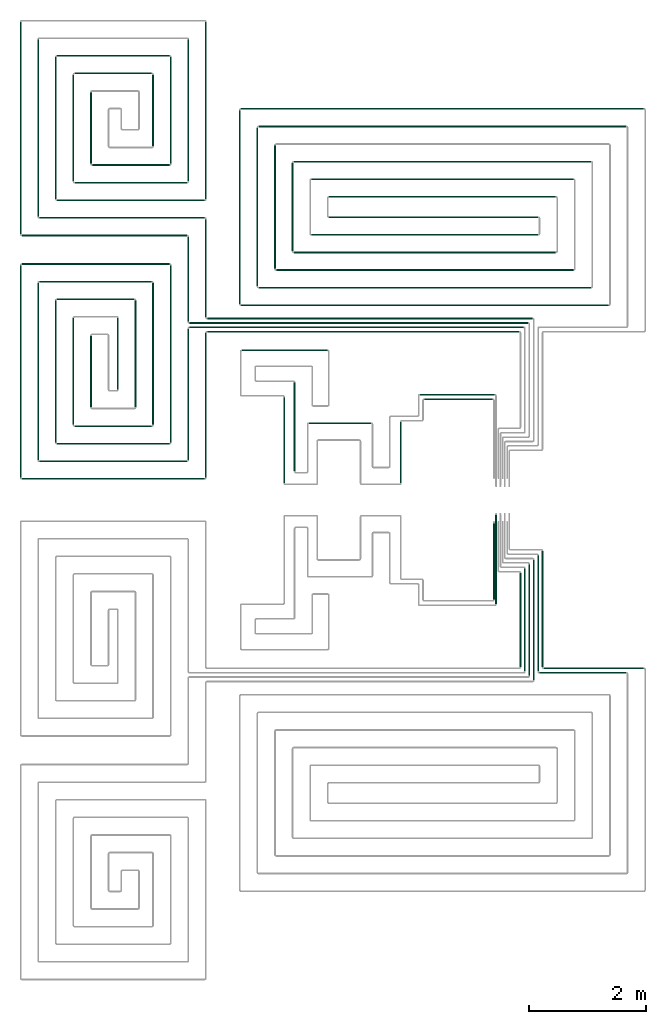
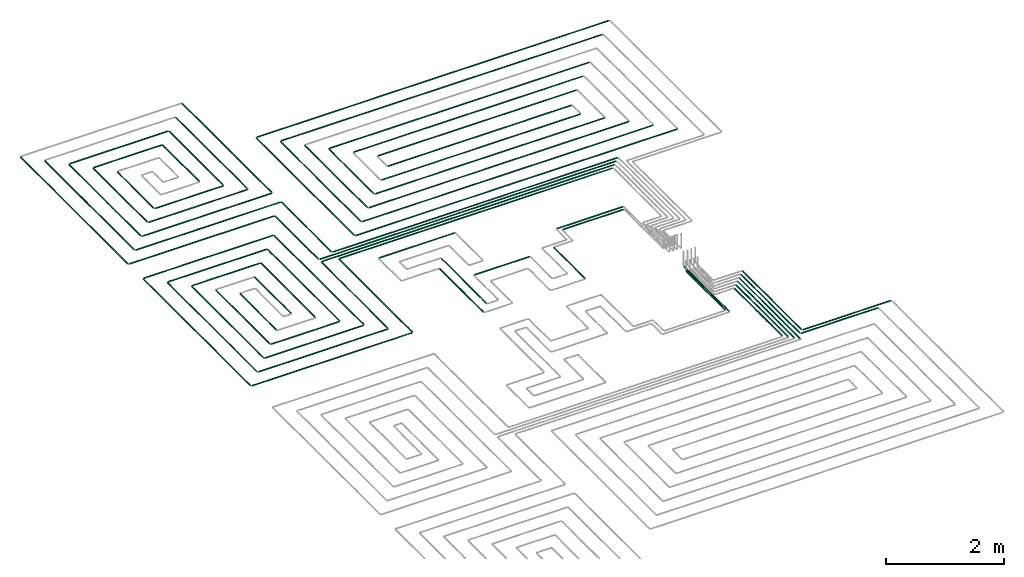
# One storey, part 2 of 12: 72 flow segments.
"""IFC2X3 building model written with IfcOpenShell, lengths in millimetres."""

from ifc_helpers import new_model, entity, si_unit, converted_unit, derived_unit, direction, frame, frame_2d, origin, origin_2d_with_axis, place, context, subcontext, project, spatial, circle, extrude, type_object, element, save


model = new_model("IFC2X3")

# Units and contexts
model_context = context("Model", 3, precision=0.01, world=origin(), true_north=direction((6.12303176911189e-17, 1.0)))
body_context = subcontext(model_context, "Body", "Model", "MODEL_VIEW")
ifc_project = project(units=[si_unit("LENGTHUNIT", "METRE", prefix="MILLI"), si_unit("AREAUNIT", "SQUARE_METRE"), si_unit("VOLUMEUNIT", "CUBIC_METRE"), converted_unit("PLANEANGLEUNIT", "DEGREE", entity("IfcRatioMeasure", 0.0174532925199433), si_unit("PLANEANGLEUNIT", "RADIAN"), dimensions=[0, 0, 0, 0, 0, 0, 0]), si_unit("MASSUNIT", "GRAM", prefix="KILO"), derived_unit("MASSDENSITYUNIT", [(si_unit("MASSUNIT", "GRAM", prefix="KILO"), 1), (si_unit("LENGTHUNIT", "METRE"), -3)]), si_unit("TIMEUNIT", "SECOND"), si_unit("FREQUENCYUNIT", "HERTZ"), si_unit("THERMODYNAMICTEMPERATUREUNIT", "DEGREE_CELSIUS"), derived_unit("THERMALTRANSMITTANCEUNIT", [(si_unit("MASSUNIT", "GRAM", prefix="KILO"), 1), (si_unit("THERMODYNAMICTEMPERATUREUNIT", "KELVIN"), -1), (si_unit("TIMEUNIT", "SECOND"), -3)]), derived_unit("VOLUMETRICFLOWRATEUNIT", [(si_unit("LENGTHUNIT", "METRE"), 3), (si_unit("TIMEUNIT", "SECOND"), -1)]), si_unit("ELECTRICCURRENTUNIT", "AMPERE"), si_unit("ELECTRICVOLTAGEUNIT", "VOLT"), si_unit("POWERUNIT", "WATT"), si_unit("FORCEUNIT", "NEWTON", prefix="KILO"), si_unit("ILLUMINANCEUNIT", "LUX"), si_unit("LUMINOUSFLUXUNIT", "LUMEN"), si_unit("LUMINOUSINTENSITYUNIT", "CANDELA"), derived_unit("USERDEFINED", [(si_unit("MASSUNIT", "GRAM", prefix="KILO"), -1), (si_unit("LENGTHUNIT", "METRE"), -2), (si_unit("TIMEUNIT", "SECOND"), 3), (si_unit("LUMINOUSFLUXUNIT", "LUMEN"), 1)]), derived_unit("LINEARVELOCITYUNIT", [(si_unit("LENGTHUNIT", "METRE"), 1), (si_unit("TIMEUNIT", "SECOND"), -1)]), si_unit("PRESSUREUNIT", "PASCAL"), derived_unit("USERDEFINED", [(si_unit("LENGTHUNIT", "METRE"), -2), (si_unit("MASSUNIT", "GRAM", prefix="KILO"), 1), (si_unit("TIMEUNIT", "SECOND"), -2)])], contexts=[model_context])

# Site, building, storey
site_placement = place(None, origin())
site = spatial("IfcSite", under=ifc_project, at=site_placement, CompositionType="ELEMENT")
building_placement = place(site_placement, origin())
building = spatial("IfcBuilding", under=site, at=building_placement, CompositionType="ELEMENT")
storey_placement = place(building_placement, frame((0.0, 0.0, 4000.0)))
storey = spatial("IfcBuildingStorey", under=building, at=storey_placement, Name="01 Level", CompositionType="ELEMENT", Elevation=4000.0)

# Flow segments
pipe_segment_type = type_object("IfcPipeSegmentType", PredefinedType="NOTDEFINED")
flow_segment_1_placement = place(storey_placement, frame((26623.6855494475, -71711.6450070283, -81.5952722359161)))
element("IfcFlowSegment", 1, at=flow_segment_1_placement, inside=storey, type_object=pipe_segment_type, context=body_context, shape_type="SweptSolid", body=[
    extrude(circle(Radius=10.0, at=origin_2d_with_axis()), frame((0.0, 11.5952722359136, 11.5952722359158), z_axis=(1.0, 0.0, 0.0), x_axis=(0.0, -1.0, 0.0)), (0.0, 0.0, 1.0), 1709.41153197237),
])
flow_segment_2_placement = place(storey_placement, frame((26548.6855494475, -71786.6450070283, -81.5952722359161)))
element("IfcFlowSegment", 2, at=flow_segment_2_placement, inside=storey, type_object=pipe_segment_type, context=body_context, shape_type="SweptSolid", body=[
    extrude(circle(Radius=10.0, at=origin_2d_with_axis()), frame((0.0, 11.5952722359136, 11.5952722359158), z_axis=(1.0, 0.0, 0.0), x_axis=(0.0, -1.0, 0.0)), (0.0, 0.0, 1.0), 1484.41153197236),
])
flow_segment_3_placement = place(storey_placement, frame((26442.0902772116, -71905.0497347924, -81.5952722359193)))
element("IfcFlowSegment", 3, at=flow_segment_3_placement, inside=storey, type_object=pipe_segment_type, context=body_context, shape_type="SweptSolid", body=[
    extrude(circle(Radius=10.0, at=origin_2d_with_axis()), frame((11.595272235918, 0.0, 11.5952722359158), z_axis=(0.0, 1.0, 0.0), x_axis=(-1.0, 0.0, 0.0)), (0.0, 0.0, 1.0), 2056.31014965248),
])
flow_segment_4_placement = place(storey_placement, frame((26367.0902772116, -71830.0497347924, -81.5952722359161)))
element("IfcFlowSegment", 4, at=flow_segment_4_placement, inside=storey, type_object=pipe_segment_type, context=body_context, shape_type="SweptSolid", body=[
    extrude(circle(Radius=10.0, at=origin_2d_with_axis()), frame((11.5952722359266, 0.0, 11.5952722359158), z_axis=(0.0, 1.0, 0.0), x_axis=(1.0, 0.0, 0.0)), (0.0, 0.0, 1.0), 1906.31014965249),
])
flow_segment_5_placement = place(storey_placement, frame((26292.0902772116, -71755.0497347924, -81.5952722359161)))
element("IfcFlowSegment", 5, at=flow_segment_5_placement, inside=storey, type_object=pipe_segment_type, context=body_context, shape_type="SweptSolid", body=[
    extrude(circle(Radius=10.0, at=origin_2d_with_axis()), frame((11.595272235918, 0.0, 11.5952722359158), z_axis=(0.0, 1.0, 0.0), x_axis=(1.0, 0.0, 0.0)), (0.0, 0.0, 1.0), 1756.31014965249),
])
flow_segment_6_placement = place(storey_placement, frame((26217.0902772116, -71680.0497347924, -81.5952722359193)))
element("IfcFlowSegment", 6, at=flow_segment_6_placement, inside=storey, type_object=pipe_segment_type, context=body_context, shape_type="SweptSolid", body=[
    extrude(circle(Radius=10.0, at=frame_2d((-4.33146851719357e-12, 0.0), x_axis=(1.0, 0.0))), frame((11.595272235918, 0.0, 11.5952722359158), z_axis=(0.0, 1.0, 0.0), x_axis=(-1.0, 0.0, 0.0)), (0.0, 0.0, 1.0), 1606.3101496525),
])
flow_segment_7_placement = place(storey_placement, frame((26592.0902772116, -71680.0497347924, -81.5952722359193)))
element("IfcFlowSegment", 7, at=flow_segment_7_placement, inside=storey, type_object=pipe_segment_type, context=body_context, shape_type="SweptSolid", body=[
    extrude(circle(Radius=10.0, at=frame_2d((4.33146851719357e-12, 0.0), x_axis=(1.0, 0.0))), frame((11.5952722359266, 0.0, 11.5952722359158), z_axis=(0.0, 1.0, 0.0), x_axis=(-1.0, 0.0, 0.0)), (0.0, 0.0, 1.0), 1981.31014965248),
])
flow_segment_8_placement = place(storey_placement, frame((26517.0902772116, -71755.0497347924, -81.5952722359161)))
element("IfcFlowSegment", 8, at=flow_segment_8_placement, inside=storey, type_object=pipe_segment_type, context=body_context, shape_type="SweptSolid", body=[
    extrude(circle(Radius=10.0, at=origin_2d_with_axis()), frame((11.5952722359266, 0.0, 11.5952722359158), z_axis=(0.0, 1.0, 0.0), x_axis=(1.0, 0.0, 0.0)), (0.0, 0.0, 1.0), 1981.31014965249),
])
flow_segment_9_placement = place(storey_placement, frame((25764.4416997349, -70531.3143518619, -81.5952722359248)))
element("IfcFlowSegment", 9, at=flow_segment_9_placement, inside=storey, type_object=pipe_segment_type, context=body_context, shape_type="SweptSolid", body=[
    extrude(circle(Radius=10.0, at=origin_2d_with_axis()), frame((11.595272235918, 0.0, 11.5952722359158), z_axis=(0.0, 1.0, 0.0), x_axis=(1.0, 0.0, 0.0)), (0.0, 0.0, 1.0), 1305.07476672193),
])
flow_segment_10_placement = place(storey_placement, frame((25799.4416997349, -70606.3143518619, -81.5952722359302)))
element("IfcFlowSegment", 10, at=flow_segment_10_placement, inside=storey, type_object=pipe_segment_type, context=body_context, shape_type="SweptSolid", body=[
    extrude(circle(Radius=10.0, at=origin_2d_with_axis()), frame((11.595272235918, 0.0, 11.5952722359158), z_axis=(0.0, 1.0, 0.0), x_axis=(1.0, 0.0, 0.0)), (0.0, 0.0, 1.0), 1520.07476672191),
])
flow_segment_11_placement = place(storey_placement, frame((20884.4386293741, -65974.0247077234, -81.5952722359175)))
element("IfcFlowSegment", 11, at=flow_segment_11_placement, inside=storey, type_object=pipe_segment_type, context=body_context, shape_type="SweptSolid", body=[
    extrude(circle(Radius=10.0, at=frame_2d((-8.66293703438714e-12, 0.0), x_axis=(1.0, 0.0))), frame((0.0, 11.595272235931, 11.5952722359158), z_axis=(1.0, 0.0, 0.0), x_axis=(0.0, 1.0, 0.0)), (0.0, 0.0, 1.0), 5324.24692007345),
])
flow_segment_12_placement = place(storey_placement, frame((20584.4386293741, -65899.0247077234, -81.5952722359161)))
element("IfcFlowSegment", 12, at=flow_segment_12_placement, inside=storey, type_object=pipe_segment_type, context=body_context, shape_type="SweptSolid", body=[
    extrude(circle(Radius=10.0, at=frame_2d((-8.66293703438714e-12, 0.0), x_axis=(1.0, 0.0))), frame((0.0, 11.5952722359223, 11.5952722359158), z_axis=(1.0, 0.0, 0.0), x_axis=(0.0, 1.0, 0.0)), (0.0, 0.0, 1.0), 5699.24692007345),
])
flow_segment_13_placement = place(storey_placement, frame((20584.4386293741, -65824.0247077234, -81.5952722359161)))
element("IfcFlowSegment", 13, at=flow_segment_13_placement, inside=storey, type_object=pipe_segment_type, context=body_context, shape_type="SweptSolid", body=[
    extrude(circle(Radius=10.0, at=frame_2d((8.66293703438714e-12, 0.0), x_axis=(1.0, 0.0))), frame((0.0, 11.595272235905, 11.5952722359158), z_axis=(1.0, 0.0, 0.0), x_axis=(0.0, 1.0, 0.0)), (0.0, 0.0, 1.0), 5774.24692007345),
])
flow_segment_14_placement = place(storey_placement, frame((20884.4386293741, -65749.0247077234, -81.5952722359161)))
element("IfcFlowSegment", 14, at=flow_segment_14_placement, inside=storey, type_object=pipe_segment_type, context=body_context, shape_type="SweptSolid", body=[
    extrude(circle(Radius=10.0, at=origin_2d_with_axis()), frame((0.0, 11.5952722359136, 11.5952722359158), z_axis=(1.0, 0.0, 0.0), x_axis=(0.0, 1.0, 0.0)), (0.0, 0.0, 1.0), 5549.24692007344),
])
flow_segment_15_placement = place(storey_placement, frame((20552.8433571382, -65792.4294354875, -81.5952722359189)))
element("IfcFlowSegment", 15, at=flow_segment_15_placement, inside=storey, type_object=pipe_segment_type, context=body_context, shape_type="SweptSolid", body=[
    extrude(circle(Radius=10.0, at=origin_2d_with_axis()), frame((11.595272235918, 0.0, 11.5952722359158), z_axis=(0.0, 1.0, 0.0), x_axis=(1.0, 0.0, 0.0)), (0.0, 0.0, 1.0), 1451.18985034759),
])
flow_segment_16_placement = place(storey_placement, frame((20852.8433571382, -65717.4294354875, -81.5952722359189)))
element("IfcFlowSegment", 16, at=flow_segment_16_placement, inside=storey, type_object=pipe_segment_type, context=body_context, shape_type="SweptSolid", body=[
    extrude(circle(Radius=10.0, at=origin_2d_with_axis()), frame((11.5952722359223, 0.0, 11.5952722359158), z_axis=(0.0, 1.0, 0.0), x_axis=(1.0, 0.0, 0.0)), (0.0, 0.0, 1.0), 1676.18985034759),
])
flow_segment_17_placement = place(storey_placement, frame((24586.730888343, -67122.7600906539, -81.5952722359261)))
element("IfcFlowSegment", 17, at=flow_segment_17_placement, inside=storey, type_object=pipe_segment_type, context=body_context, shape_type="SweptSolid", body=[
    extrude(circle(Radius=10.0, at=origin_2d_with_axis()), frame((0.0, 11.5952722359483, 11.5952722359158), z_axis=(1.0, 0.0, 0.0), x_axis=(0.0, -1.0, 0.0)), (0.0, 0.0, 1.0), 1169.30608362779),
])
flow_segment_18_placement = place(storey_placement, frame((20852.8433571382, -68451.2395851399, -81.5952722359189)))
element("IfcFlowSegment", 18, at=flow_segment_18_placement, inside=storey, type_object=pipe_segment_type, context=body_context, shape_type="SweptSolid", body=[
    extrude(circle(Radius=10.0, at=origin_2d_with_axis()), frame((11.5952722359439, 0.0, 11.5952722359158), z_axis=(0.0, 1.0, 0.0), x_axis=(1.0, 0.0, 0.0)), (0.0, 0.0, 1.0), 2468.81014965244),
])
flow_segment_19_placement = place(storey_placement, frame((20552.8433571382, -68151.2395851399, -81.5952722359189)))
element("IfcFlowSegment", 19, at=flow_segment_19_placement, inside=storey, type_object=pipe_segment_type, context=body_context, shape_type="SweptSolid", body=[
    extrude(circle(Radius=10.0, at=frame_2d((8.66293703438714e-12, 0.0), x_axis=(1.0, 0.0))), frame((11.5952722359266, 0.0, 11.5952722359158), z_axis=(0.0, 1.0, 0.0), x_axis=(-1.0, 0.0, 0.0)), (0.0, 0.0, 1.0), 2243.81014965244),
])
flow_segment_20_placement = place(storey_placement, frame((17725.6253473195, -68482.8348573758, -81.5952722359189)))
element("IfcFlowSegment", 20, at=flow_segment_20_placement, inside=storey, type_object=pipe_segment_type, context=body_context, shape_type="SweptSolid", body=[
    extrude(circle(Radius=10.0, at=frame_2d((1.73258740687743e-11, 0.0), x_axis=(1.0, 0.0))), frame((0.0, 11.595272235931, 11.5952722359158), z_axis=(1.0, 0.0, 0.0), x_axis=(0.0, 1.0, 0.0)), (0.0, 0.0, 1.0), 3118.81328205467),
])
flow_segment_21_placement = place(storey_placement, frame((18025.6253473195, -68182.8348573758, -81.5952722359189)))
element("IfcFlowSegment", 21, at=flow_segment_21_placement, inside=storey, type_object=pipe_segment_type, context=body_context, shape_type="SweptSolid", body=[
    extrude(circle(Radius=10.0, at=frame_2d((8.66293703438714e-12, 0.0), x_axis=(1.0, 0.0))), frame((0.0, 11.5952722359223, 11.5952722359158), z_axis=(1.0, 0.0, 0.0), x_axis=(0.0, 1.0, 0.0)), (0.0, 0.0, 1.0), 2518.81328205467),
])
flow_segment_22_placement = place(storey_placement, frame((17994.0300750835, -68151.2395851399, -81.5952722359202)))
element("IfcFlowSegment", 22, at=flow_segment_22_placement, inside=storey, type_object=pipe_segment_type, context=body_context, shape_type="SweptSolid", body=[
    extrude(circle(Radius=10.0, at=origin_2d_with_axis()), frame((11.5952722359439, 0.0, 11.5952722359158), z_axis=(0.0, 1.0, 0.0), x_axis=(1.0, 0.0, 0.0)), (0.0, 0.0, 1.0), 3023.35825128324),
])
flow_segment_23_placement = place(storey_placement, frame((17694.0300750835, -68451.2395851399, -81.5952722359202)))
element("IfcFlowSegment", 23, at=flow_segment_23_placement, inside=storey, type_object=pipe_segment_type, context=body_context, shape_type="SweptSolid", body=[
    extrude(circle(Radius=10.0, at=origin_2d_with_axis()), frame((11.5952722359374, 0.0, 11.5952722359158), z_axis=(0.0, 1.0, 0.0), x_axis=(1.0, 0.0, 0.0)), (0.0, 0.0, 1.0), 3623.35825128323),
])
flow_segment_24_placement = place(storey_placement, frame((18025.6253473194, -65119.4766060926, -81.5952722359189)))
element("IfcFlowSegment", 24, at=flow_segment_24_placement, inside=storey, type_object=pipe_segment_type, context=body_context, shape_type="SweptSolid", body=[
    extrude(circle(Radius=10.0, at=frame_2d((8.66293703438714e-12, 0.0), x_axis=(1.0, 0.0))), frame((0.0, 11.595272235905, 11.5952722359158), z_axis=(1.0, 0.0, 0.0), x_axis=(0.0, 1.0, 0.0)), (0.0, 0.0, 1.0), 1918.81328205468),
])
flow_segment_25_placement = place(storey_placement, frame((17725.6253473194, -64819.4766060926, -81.5952722359175)))
element("IfcFlowSegment", 25, at=flow_segment_25_placement, inside=storey, type_object=pipe_segment_type, context=body_context, shape_type="SweptSolid", body=[
    extrude(circle(Radius=10.0, at=frame_2d((8.66293703438714e-12, 0.0), x_axis=(1.0, 0.0))), frame((0.0, 11.5952722359136, 11.5952722359158), z_axis=(1.0, 0.0, 0.0), x_axis=(0.0, 1.0, 0.0)), (0.0, 0.0, 1.0), 2518.81328205467),
])
flow_segment_26_placement = place(storey_placement, frame((20252.8433571382, -67851.2395851399, -81.595272235922)))
element("IfcFlowSegment", 26, at=flow_segment_26_placement, inside=storey, type_object=pipe_segment_type, context=body_context, shape_type="SweptSolid", body=[
    extrude(circle(Radius=10.0, at=origin_2d_with_axis()), frame((11.5952722359439, 0.0, 11.5952722359158), z_axis=(0.0, 1.0, 0.0), x_axis=(1.0, 0.0, 0.0)), (0.0, 0.0, 1.0), 3023.35825128323),
])
flow_segment_27_placement = place(storey_placement, frame((19952.8433571382, -67551.2395851399, -81.5952722359189)))
element("IfcFlowSegment", 27, at=flow_segment_27_placement, inside=storey, type_object=pipe_segment_type, context=body_context, shape_type="SweptSolid", body=[
    extrude(circle(Radius=10.0, at=frame_2d((1.29944055515807e-11, 0.0), x_axis=(1.0, 0.0))), frame((11.595272235931, 0.0, 11.5952722359158), z_axis=(0.0, 1.0, 0.0), x_axis=(-1.0, 0.0, 0.0)), (0.0, 0.0, 1.0), 2423.35825128325),
])
flow_segment_28_placement = place(storey_placement, frame((18325.6253473195, -67882.8348573759, -81.595272235922)))
element("IfcFlowSegment", 28, at=flow_segment_28_placement, inside=storey, type_object=pipe_segment_type, context=body_context, shape_type="SweptSolid", body=[
    extrude(circle(Radius=10.0, at=origin_2d_with_axis()), frame((0.0, 11.5952722359136, 11.5952722359158), z_axis=(1.0, 0.0, 0.0), x_axis=(0.0, -1.0, 0.0)), (0.0, 0.0, 1.0), 1918.8132820547),
])
flow_segment_29_placement = place(storey_placement, frame((18625.6253473194, -67582.8348573759, -81.5952722359202)))
element("IfcFlowSegment", 29, at=flow_segment_29_placement, inside=storey, type_object=pipe_segment_type, context=body_context, shape_type="SweptSolid", body=[
    extrude(circle(Radius=10.0, at=frame_2d((8.66293703438714e-12, 0.0), x_axis=(1.0, 0.0))), frame((0.0, 11.5952722359136, 11.5952722359158), z_axis=(1.0, 0.0, 0.0), x_axis=(0.0, 1.0, 0.0)), (0.0, 0.0, 1.0), 1318.8132820547),
])
flow_segment_30_placement = place(storey_placement, frame((18594.0300750835, -67551.2395851399, -81.595272235922)))
element("IfcFlowSegment", 30, at=flow_segment_30_placement, inside=storey, type_object=pipe_segment_type, context=body_context, shape_type="SweptSolid", body=[
    extrude(circle(Radius=10.0, at=origin_2d_with_axis()), frame((11.5952722359418, 0.0, 11.5952722359158), z_axis=(0.0, 1.0, 0.0), x_axis=(1.0, 0.0, 0.0)), (0.0, 0.0, 1.0), 1823.35825128327),
])
flow_segment_31_placement = place(storey_placement, frame((18294.0300750835, -67851.2395851399, -81.595272235922)))
element("IfcFlowSegment", 31, at=flow_segment_31_placement, inside=storey, type_object=pipe_segment_type, context=body_context, shape_type="SweptSolid", body=[
    extrude(circle(Radius=10.0, at=origin_2d_with_axis()), frame((11.5952722359396, 0.0, 11.5952722359158), z_axis=(0.0, 1.0, 0.0), x_axis=(1.0, 0.0, 0.0)), (0.0, 0.0, 1.0), 2423.35825128326),
])
flow_segment_32_placement = place(storey_placement, frame((18325.6253473194, -65419.4766060926, -81.595272235922)))
element("IfcFlowSegment", 32, at=flow_segment_32_placement, inside=storey, type_object=pipe_segment_type, context=body_context, shape_type="SweptSolid", body=[
    extrude(circle(Radius=10.0, at=frame_2d((8.66293703438714e-12, 0.0), x_axis=(1.0, 0.0))), frame((0.0, 11.5952722359136, 11.5952722359158), z_axis=(1.0, 0.0, 0.0), x_axis=(0.0, 1.0, 0.0)), (0.0, 0.0, 1.0), 1318.81328205471),
])
flow_segment_33_placement = place(storey_placement, frame((19652.8433571382, -67251.2395851399, -81.5952722359234)))
element("IfcFlowSegment", 33, at=flow_segment_33_placement, inside=storey, type_object=pipe_segment_type, context=body_context, shape_type="SweptSolid", body=[
    extrude(circle(Radius=10.0, at=origin_2d_with_axis()), frame((11.595272235931, 0.0, 11.5952722359158), z_axis=(0.0, 1.0, 0.0), x_axis=(1.0, 0.0, 0.0)), (0.0, 0.0, 1.0), 1823.35825128327),
])
flow_segment_34_placement = place(storey_placement, frame((19352.8433571382, -66951.2395851399, -81.5952722359229)))
element("IfcFlowSegment", 34, at=flow_segment_34_placement, inside=storey, type_object=pipe_segment_type, context=body_context, shape_type="SweptSolid", body=[
    extrude(circle(Radius=10.0, at=frame_2d((-2.16573425859679e-12, 0.0), x_axis=(1.0, 0.0))), frame((11.595272235931, 0.0, 11.5952722359158), z_axis=(0.0, 1.0, 0.0), x_axis=(1.0, 0.0, 0.0)), (0.0, 0.0, 1.0), 1223.35825128328),
])
flow_segment_35_placement = place(storey_placement, frame((18894.0300750835, -67251.23958514, -81.5952722359239)))
element("IfcFlowSegment", 35, at=flow_segment_35_placement, inside=storey, type_object=pipe_segment_type, context=body_context, shape_type="SweptSolid", body=[
    extrude(circle(Radius=10.0, at=origin_2d_with_axis()), frame((11.5952722359374, 0.0, 11.5952722359158), z_axis=(0.0, 1.0, 0.0), x_axis=(1.0, 0.0, 0.0)), (0.0, 0.0, 1.0), 1223.35825128332),
])
flow_segment_36_placement = place(storey_placement, frame((20852.8433571382, -63701.2395851399, -81.5952722359198)))
element("IfcFlowSegment", 36, at=flow_segment_36_placement, inside=storey, type_object=pipe_segment_type, context=body_context, shape_type="SweptSolid", body=[
    extrude(circle(Radius=10.0, at=origin_2d_with_axis()), frame((11.5952722359439, 0.0, 11.5952722359158), z_axis=(0.0, 1.0, 0.0), x_axis=(1.0, 0.0, 0.0)), (0.0, 0.0, 1.0), 3023.35825128325),
])
flow_segment_37_placement = place(storey_placement, frame((20552.8433571382, -63401.2395851399, -81.5952722359179)))
element("IfcFlowSegment", 37, at=flow_segment_37_placement, inside=storey, type_object=pipe_segment_type, context=body_context, shape_type="SweptSolid", body=[
    extrude(circle(Radius=10.0, at=frame_2d((8.66293703438714e-12, 0.0), x_axis=(1.0, 0.0))), frame((11.5952722359266, 0.0, 11.5952722359158), z_axis=(0.0, 1.0, 0.0), x_axis=(-1.0, 0.0, 0.0)), (0.0, 0.0, 1.0), 2423.35825128326),
])
flow_segment_38_placement = place(storey_placement, frame((17994.0300750835, -64001.2395851399, -81.595272235922)))
element("IfcFlowSegment", 38, at=flow_segment_38_placement, inside=storey, type_object=pipe_segment_type, context=body_context, shape_type="SweptSolid", body=[
    extrude(circle(Radius=10.0, at=origin_2d_with_axis()), frame((11.5952722359526, 0.0, 11.5952722359158), z_axis=(0.0, 1.0, 0.0), x_axis=(1.0, 0.0, 0.0)), (0.0, 0.0, 1.0), 3023.35825128327),
])
flow_segment_39_placement = place(storey_placement, frame((17694.0300750835, -64301.2395851399, -81.595272235922)))
element("IfcFlowSegment", 39, at=flow_segment_39_placement, inside=storey, type_object=pipe_segment_type, context=body_context, shape_type="SweptSolid", body=[
    extrude(circle(Radius=10.0, at=origin_2d_with_axis()), frame((11.5952722359483, 0.0, 11.5952722359158), z_axis=(0.0, 1.0, 0.0), x_axis=(1.0, 0.0, 0.0)), (0.0, 0.0, 1.0), 3623.35825128325),
])
flow_segment_40_placement = place(storey_placement, frame((20252.8433571382, -63101.23958514, -81.5952722359229)))
element("IfcFlowSegment", 40, at=flow_segment_40_placement, inside=storey, type_object=pipe_segment_type, context=body_context, shape_type="SweptSolid", body=[
    extrude(circle(Radius=10.0, at=origin_2d_with_axis()), frame((11.5952722359439, 0.0, 11.5952722359158), z_axis=(0.0, 1.0, 0.0), x_axis=(1.0, 0.0, 0.0)), (0.0, 0.0, 1.0), 1823.35825128329),
])
flow_segment_41_placement = place(storey_placement, frame((19952.8433571382, -62801.2395851399, -81.5952722359202)))
element("IfcFlowSegment", 41, at=flow_segment_41_placement, inside=storey, type_object=pipe_segment_type, context=body_context, shape_type="SweptSolid", body=[
    extrude(circle(Radius=10.0, at=frame_2d((8.66293703438714e-12, 0.0), x_axis=(1.0, 0.0))), frame((11.5952722359266, 0.0, 11.5952722359158), z_axis=(0.0, 1.0, 0.0), x_axis=(-1.0, 0.0, 0.0)), (0.0, 0.0, 1.0), 1223.35825128325),
])
flow_segment_42_placement = place(storey_placement, frame((18594.0300750835, -63401.23958514, -81.5952722359284)))
element("IfcFlowSegment", 42, at=flow_segment_42_placement, inside=storey, type_object=pipe_segment_type, context=body_context, shape_type="SweptSolid", body=[
    extrude(circle(Radius=10.0, at=frame_2d((1.51601398101775e-11, 0.0), x_axis=(1.0, 0.0))), frame((11.595272235931, 0.0, 11.5952722359158), z_axis=(0.0, 1.0, 0.0), x_axis=(-1.0, 0.0, 0.0)), (0.0, 0.0, 1.0), 1823.35825128331),
])
flow_segment_43_placement = place(storey_placement, frame((18294.0300750835, -63701.23958514, -81.5952722359261)))
element("IfcFlowSegment", 43, at=flow_segment_43_placement, inside=storey, type_object=pipe_segment_type, context=body_context, shape_type="SweptSolid", body=[
    extrude(circle(Radius=10.0, at=frame_2d((1.51601398101775e-11, 0.0), x_axis=(1.0, 0.0))), frame((11.5952722359331, 0.0, 11.5952722359158), z_axis=(0.0, 1.0, 0.0), x_axis=(-1.0, 0.0, 0.0)), (0.0, 0.0, 1.0), 2423.35825128329),
])
flow_segment_44_placement = place(storey_placement, frame((18894.0300750835, -63101.23958514, -81.5952722359257)))
element("IfcFlowSegment", 44, at=flow_segment_44_placement, inside=storey, type_object=pipe_segment_type, context=body_context, shape_type="SweptSolid", body=[
    extrude(circle(Radius=10.0, at=origin_2d_with_axis()), frame((11.5952722359504, 0.0, 11.5952722359158), z_axis=(0.0, 1.0, 0.0), x_axis=(1.0, 0.0, 0.0)), (0.0, 0.0, 1.0), 1223.35825128335),
])
for number, where in (
    (45, (17725.6253473195, -64332.8348573759, -81.5952722359175)),
    (46, (18025.6253473195, -64032.8348573759, -81.595272235917)),
):
    element("IfcFlowSegment", number, at=place(storey_placement, frame(where)), inside=storey, type_object=pipe_segment_type, context=body_context, shape_type="SweptSolid", body=[
        extrude(circle(Radius=10.0, at=frame_2d((2.59888111031614e-11, 0.0), x_axis=(1.0, 0.0))), frame((0.0, 11.5952722359396, 11.5952722359158), z_axis=(1.0, 0.0, 0.0), x_axis=(0.0, 1.0, 0.0)), (0.0, 0.0, 1.0), 2818.81328205464),
    ])
flow_segment_45_placement = place(storey_placement, frame((18325.6253473195, -63732.8348573759, -81.5952722359198)))
element("IfcFlowSegment", 47, at=flow_segment_45_placement, inside=storey, type_object=pipe_segment_type, context=body_context, shape_type="SweptSolid", body=[
    extrude(circle(Radius=10.0, at=frame_2d((1.73258740687743e-11, 0.0), x_axis=(1.0, 0.0))), frame((0.0, 11.595272235931, 11.5952722359158), z_axis=(1.0, 0.0, 0.0), x_axis=(0.0, 1.0, 0.0)), (0.0, 0.0, 1.0), 2518.8132820547),
])
flow_segment_46_placement = place(storey_placement, frame((18625.6253473194, -63432.8348573759, -81.5952722359202)))
element("IfcFlowSegment", 48, at=flow_segment_46_placement, inside=storey, type_object=pipe_segment_type, context=body_context, shape_type="SweptSolid", body=[
    extrude(circle(Radius=10.0, at=frame_2d((1.73258740687743e-11, 0.0), x_axis=(1.0, 0.0))), frame((0.0, 11.595272235931, 11.5952722359158), z_axis=(1.0, 0.0, 0.0), x_axis=(0.0, 1.0, 0.0)), (0.0, 0.0, 1.0), 1918.8132820547),
])
flow_segment_47_placement = place(storey_placement, frame((18625.6253473194, -61569.4766060926, -81.5952722359202)))
element("IfcFlowSegment", 49, at=flow_segment_47_placement, inside=storey, type_object=pipe_segment_type, context=body_context, shape_type="SweptSolid", body=[
    extrude(circle(Radius=10.0, at=origin_2d_with_axis()), frame((0.0, 11.5952722359136, 11.5952722359158), z_axis=(1.0, 0.0, 0.0), x_axis=(0.0, 1.0, 0.0)), (0.0, 0.0, 1.0), 1318.81328205473),
])
flow_segment_48_placement = place(storey_placement, frame((18325.6253473194, -61269.4766060926, -81.5952722359198)))
element("IfcFlowSegment", 50, at=flow_segment_48_placement, inside=storey, type_object=pipe_segment_type, context=body_context, shape_type="SweptSolid", body=[
    extrude(circle(Radius=10.0, at=origin_2d_with_axis()), frame((0.0, 11.5952722359136, 11.5952722359158), z_axis=(1.0, 0.0, 0.0), x_axis=(0.0, 1.0, 0.0)), (0.0, 0.0, 1.0), 1918.81328205471),
])
flow_segment_49_placement = place(storey_placement, frame((18925.6253473194, -63132.8348573759, -81.5952722359229)))
element("IfcFlowSegment", 51, at=flow_segment_49_placement, inside=storey, type_object=pipe_segment_type, context=body_context, shape_type="SweptSolid", body=[
    extrude(circle(Radius=10.0, at=frame_2d((8.66293703438714e-12, 0.0), x_axis=(1.0, 0.0))), frame((0.0, 11.5952722359136, 11.5952722359158), z_axis=(1.0, 0.0, 0.0), x_axis=(0.0, 1.0, 0.0)), (0.0, 0.0, 1.0), 1318.81328205473),
])
flow_segment_50_placement = place(storey_placement, frame((21730.6562350407, -65190.4944566176, -81.5952722359266)))
element("IfcFlowSegment", 52, at=flow_segment_50_placement, inside=storey, type_object=pipe_segment_type, context=body_context, shape_type="SweptSolid", body=[
    extrude(circle(Radius=10.0, at=origin_2d_with_axis()), frame((11.5952722359699, 0.0, 11.5952722359158), z_axis=(0.0, 1.0, 0.0), x_axis=(1.0, 0.0, 0.0)), (0.0, 0.0, 1.0), 2707.85893213097),
])
flow_segment_51_placement = place(storey_placement, frame((21430.6562350407, -65490.4944566176, -81.595272235928)))
element("IfcFlowSegment", 53, at=flow_segment_51_placement, inside=storey, type_object=pipe_segment_type, context=body_context, shape_type="SweptSolid", body=[
    extrude(circle(Radius=10.0, at=origin_2d_with_axis()), frame((11.5952722359526, 0.0, 11.5952722359158), z_axis=(0.0, 1.0, 0.0), x_axis=(1.0, 0.0, 0.0)), (0.0, 0.0, 1.0), 3307.85893213096),
])
flow_segment_52_placement = place(storey_placement, frame((22330.6562350407, -64590.4944566176, -81.595272235932)))
element("IfcFlowSegment", 54, at=flow_segment_52_placement, inside=storey, type_object=pipe_segment_type, context=body_context, shape_type="SweptSolid", body=[
    extrude(circle(Radius=10.0, at=origin_2d_with_axis()), frame((11.5952722359526, 0.0, 11.5952722359158), z_axis=(0.0, 1.0, 0.0), x_axis=(1.0, 0.0, 0.0)), (0.0, 0.0, 1.0), 1507.858932131),
])
flow_segment_53_placement = place(storey_placement, frame((22030.6562350407, -64890.4944566176, -81.595272235933)))
element("IfcFlowSegment", 55, at=flow_segment_53_placement, inside=storey, type_object=pipe_segment_type, context=body_context, shape_type="SweptSolid", body=[
    extrude(circle(Radius=10.0, at=origin_2d_with_axis()), frame((11.5952722359483, 0.0, 11.5952722359158), z_axis=(0.0, 1.0, 0.0), x_axis=(1.0, 0.0, 0.0)), (0.0, 0.0, 1.0), 2107.85893213099),
])
flow_segment_54_placement = place(storey_placement, frame((21762.2515072766, -62474.2307967226, -81.5952722359275)))
element("IfcFlowSegment", 56, at=flow_segment_54_placement, inside=storey, type_object=pipe_segment_type, context=body_context, shape_type="SweptSolid", body=[
    extrude(circle(Radius=10.0, at=origin_2d_with_axis()), frame((0.0, 11.5952722359136, 11.5952722359158), z_axis=(1.0, 0.0, 0.0), x_axis=(0.0, -1.0, 0.0)), (0.0, 0.0, 1.0), 6270.84557414324),
])
flow_segment_55_placement = place(storey_placement, frame((21462.2515072766, -62174.2307967226, -81.5952722359161)))
element("IfcFlowSegment", 57, at=flow_segment_55_placement, inside=storey, type_object=pipe_segment_type, context=body_context, shape_type="SweptSolid", body=[
    extrude(circle(Radius=10.0, at=origin_2d_with_axis()), frame((0.0, 11.5952722359136, 11.5952722359158), z_axis=(1.0, 0.0, 0.0), x_axis=(0.0, 1.0, 0.0)), (0.0, 0.0, 1.0), 6870.84557414322),
])
flow_segment_56_placement = place(storey_placement, frame((22362.2515072766, -63074.2307967226, -81.5952722359229)))
element("IfcFlowSegment", 58, at=flow_segment_56_placement, inside=storey, type_object=pipe_segment_type, context=body_context, shape_type="SweptSolid", body=[
    extrude(circle(Radius=10.0, at=frame_2d((-8.66293703438714e-12, 0.0), x_axis=(1.0, 0.0))), frame((0.0, 11.5952722359223, 11.5952722359158), z_axis=(1.0, 0.0, 0.0), x_axis=(0.0, 1.0, 0.0)), (0.0, 0.0, 1.0), 5070.84557414327),
])
flow_segment_57_placement = place(storey_placement, frame((21462.2515072767, -65522.0897288535, -81.5952722359266)))
element("IfcFlowSegment", 59, at=flow_segment_57_placement, inside=storey, type_object=pipe_segment_type, context=body_context, shape_type="SweptSolid", body=[
    extrude(circle(Radius=10.0, at=frame_2d((6.064055924071e-11, 0.0), x_axis=(1.0, 0.0))), frame((0.0, 11.5952722359743, 11.5952722359158), z_axis=(1.0, 0.0, 0.0), x_axis=(0.0, 1.0, 0.0)), (0.0, 0.0, 1.0), 6270.84557414324),
])
flow_segment_58_placement = place(storey_placement, frame((21762.2515072767, -65222.0897288535, -81.5952722359166)))
element("IfcFlowSegment", 60, at=flow_segment_58_placement, inside=storey, type_object=pipe_segment_type, context=body_context, shape_type="SweptSolid", body=[
    extrude(circle(Radius=10.0, at=frame_2d((5.19776222063229e-11, 0.0), x_axis=(1.0, 0.0))), frame((0.0, 11.5952722359656, 11.5952722359158), z_axis=(1.0, 0.0, 0.0), x_axis=(0.0, 1.0, 0.0)), (0.0, 0.0, 1.0), 5670.84557414323),
])
flow_segment_59_placement = place(storey_placement, frame((22062.2515072766, -64922.0897288535, -81.5952722359248)))
element("IfcFlowSegment", 61, at=flow_segment_59_placement, inside=storey, type_object=pipe_segment_type, context=body_context, shape_type="SweptSolid", body=[
    extrude(circle(Radius=10.0, at=frame_2d((3.46517481375486e-11, 0.0), x_axis=(1.0, 0.0))), frame((0.0, 11.5952722359483, 11.5952722359158), z_axis=(1.0, 0.0, 0.0), x_axis=(0.0, 1.0, 0.0)), (0.0, 0.0, 1.0), 5070.84557414326),
])
flow_segment_60_placement = place(storey_placement, frame((22362.2515072766, -64622.0897288535, -81.5952722359198)))
element("IfcFlowSegment", 62, at=flow_segment_60_placement, inside=storey, type_object=pipe_segment_type, context=body_context, shape_type="SweptSolid", body=[
    extrude(circle(Radius=10.0, at=frame_2d((2.59888111031614e-11, 0.0), x_axis=(1.0, 0.0))), frame((0.0, 11.5952722359483, 11.5952722359158), z_axis=(1.0, 0.0, 0.0), x_axis=(0.0, 1.0, 0.0)), (0.0, 0.0, 1.0), 4470.84557414325),
])
flow_segment_61_placement = place(storey_placement, frame((22962.2515072766, -63674.2307967225, -81.5952722359393)))
element("IfcFlowSegment", 63, at=flow_segment_61_placement, inside=storey, type_object=pipe_segment_type, context=body_context, shape_type="SweptSolid", body=[
    extrude(circle(Radius=10.0, at=origin_2d_with_axis()), frame((0.0, 11.5952722359223, 11.5952722359158), z_axis=(1.0, 0.0, 0.0), x_axis=(0.0, -1.0, 0.0)), (0.0, 0.0, 1.0), 3870.84557414329),
])
flow_segment_62_placement = place(storey_placement, frame((22662.2515072766, -63374.2307967225, -81.595272235933)))
element("IfcFlowSegment", 64, at=flow_segment_62_placement, inside=storey, type_object=pipe_segment_type, context=body_context, shape_type="SweptSolid", body=[
    extrude(circle(Radius=10.0, at=origin_2d_with_axis()), frame((0.0, 11.595272235905, 11.5952722359158), z_axis=(1.0, 0.0, 0.0), x_axis=(0.0, -1.0, 0.0)), (0.0, 0.0, 1.0), 4470.84557414328),
])
flow_segment_63_placement = place(storey_placement, frame((22662.2515072766, -64322.0897288535, -81.5952722359266)))
element("IfcFlowSegment", 65, at=flow_segment_63_placement, inside=storey, type_object=pipe_segment_type, context=body_context, shape_type="SweptSolid", body=[
    extrude(circle(Radius=10.0, at=frame_2d((3.46517481375486e-11, 0.0), x_axis=(1.0, 0.0))), frame((0.0, 11.5952722359483, 11.5952722359158), z_axis=(1.0, 0.0, 0.0), x_axis=(0.0, 1.0, 0.0)), (0.0, 0.0, 1.0), 3870.84557414328),
])
flow_segment_64_placement = place(storey_placement, frame((22962.2515072766, -64022.0897288535, -81.5952722359275)))
element("IfcFlowSegment", 66, at=flow_segment_64_placement, inside=storey, type_object=pipe_segment_type, context=body_context, shape_type="SweptSolid", body=[
    extrude(circle(Radius=10.0, at=frame_2d((5.19776222063229e-11, 0.0), x_axis=(1.0, 0.0))), frame((0.0, 11.5952722359656, 11.5952722359158), z_axis=(1.0, 0.0, 0.0), x_axis=(0.0, 1.0, 0.0)), (0.0, 0.0, 1.0), 3570.8455741433),
])
flow_segment_65_placement = place(storey_placement, frame((24174.4137837032, -68544.4393916874, -81.5952722359302)))
element("IfcFlowSegment", 67, at=flow_segment_65_placement, inside=storey, type_object=pipe_segment_type, context=body_context, shape_type="SweptSolid", body=[
    extrude(circle(Radius=10.0, at=origin_2d_with_axis()), frame((11.5952722359786, 0.0, 11.5952722359158), z_axis=(0.0, 1.0, 0.0), x_axis=(1.0, 0.0, 0.0)), (0.0, 0.0, 1.0), 1044.42186360162),
])
flow_segment_66_placement = place(storey_placement, frame((21476.9829033853, -66291.7494840976, -81.5952722359293)))
element("IfcFlowSegment", 68, at=flow_segment_66_placement, inside=storey, type_object=pipe_segment_type, context=body_context, shape_type="SweptSolid", body=[
    extrude(circle(Radius=10.0, at=frame_2d((8.66293703438714e-12, 0.0), x_axis=(1.0, 0.0))), frame((0.0, 11.595272235905, 11.5952722359158), z_axis=(1.0, 0.0, 0.0), x_axis=(0.0, 1.0, 0.0)), (0.0, 0.0, 1.0), 1461.77751147482),
])
flow_segment_67_placement = place(storey_placement, frame((22190.153709968, -68544.4393916874, -81.5952722359302)))
element("IfcFlowSegment", 69, at=flow_segment_67_placement, inside=storey, type_object=pipe_segment_type, context=body_context, shape_type="SweptSolid", body=[
    extrude(circle(Radius=10.0, at=origin_2d_with_axis()), frame((11.5952722359266, 0.0, 11.5952722359158), z_axis=(0.0, 1.0, 0.0), x_axis=(1.0, 0.0, 0.0)), (0.0, 0.0, 1.0), 1468.19980654745),
])
flow_segment_68_placement = place(storey_placement, frame((22365.153709968, -68344.4393916874, -81.5952722359225)))
element("IfcFlowSegment", 70, at=flow_segment_68_placement, inside=storey, type_object=pipe_segment_type, context=body_context, shape_type="SweptSolid", body=[
    extrude(circle(Radius=10.0, at=origin_2d_with_axis()), frame((11.5952722359266, 0.0, 11.5952722359158), z_axis=(0.0, 1.0, 0.0), x_axis=(1.0, 0.0, 0.0)), (0.0, 0.0, 1.0), 1518.19980654744),
])
flow_segment_69_placement = place(storey_placement, frame((24511.730888343, -67047.7600906539, -81.5952722359257)))
element("IfcFlowSegment", 71, at=flow_segment_69_placement, inside=storey, type_object=pipe_segment_type, context=body_context, shape_type="SweptSolid", body=[
    extrude(circle(Radius=10.0, at=origin_2d_with_axis()), frame((0.0, 11.5952722359136, 11.5952722359158), z_axis=(1.0, 0.0, 0.0), x_axis=(0.0, -1.0, 0.0)), (0.0, 0.0, 1.0), 1279.3060836278),
])
flow_segment_70_placement = place(storey_placement, frame((22622.1485075651, -67532.8348573758, -81.5952722359339)))
element("IfcFlowSegment", 72, at=flow_segment_70_placement, inside=storey, type_object=pipe_segment_type, context=body_context, shape_type="SweptSolid", body=[
    extrude(circle(Radius=10.0, at=origin_2d_with_axis()), frame((0.0, 11.595272235931, 11.5952722359158), z_axis=(1.0, 0.0, 0.0), x_axis=(0.0, 1.0, 0.0)), (0.0, 0.0, 1.0), 1062.80764523384),
])

save(model, "model.ifc")
